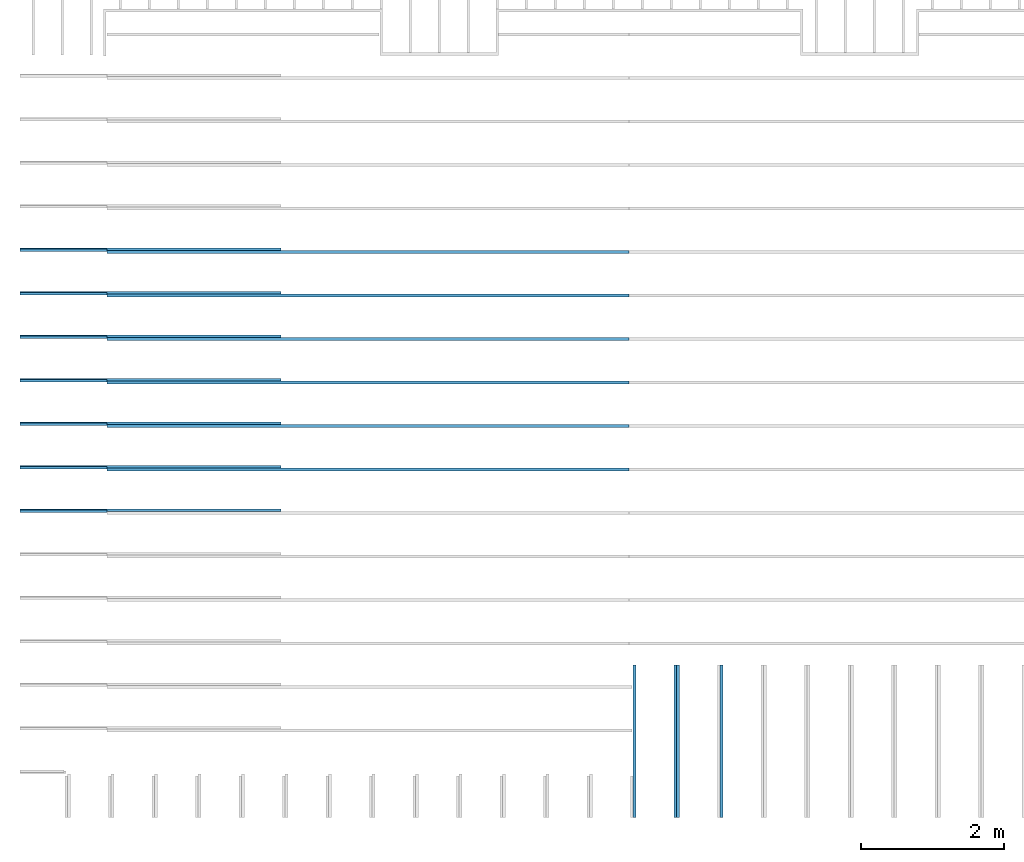
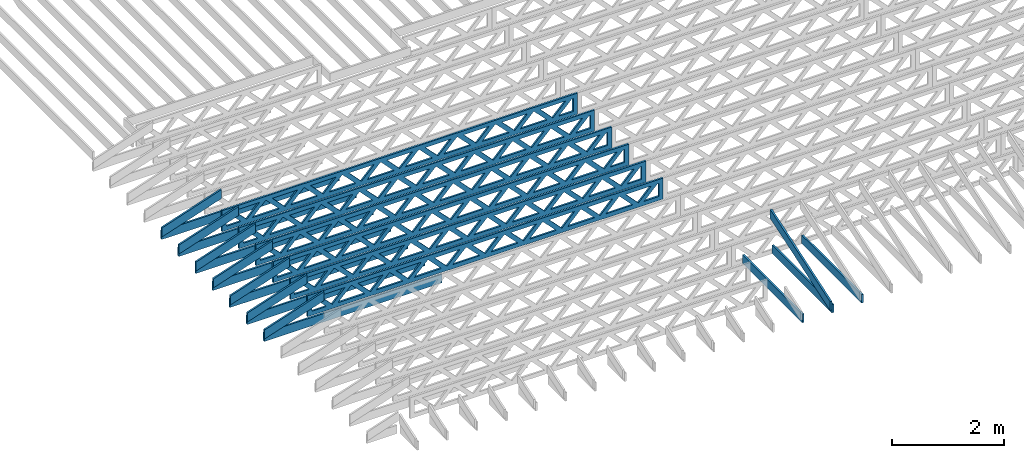
# One storey, part 2 of 18: 24 beams, 5 elements without a shape of their own.
"""IFC4 building model written with IfcOpenShell, lengths in feet."""

from ifc_helpers import new_model, entity, si_unit, converted_unit, derived_unit, direction, frame, frame_2d, origin, origin_2d_with_axis, place, context, subcontext, project, spatial, rectangle, extrude, clip, halfspace, source, transform, mapped, material, material_profile, profile_set, profile_usage, type_object, type_shapes, element, aggregate, save


model = new_model("IFC4")

# Units and contexts
model_context_1 = context("Model", 3, precision=0.0001, world=origin(), true_north=direction((6.12303176911189e-17, 1.0)))
model_context_2 = context("Model", 3, precision=0.0001, world=origin(), true_north=direction((6.12303176911189e-17, 1.0)))
body_context = subcontext(model_context_2, "Body", "Model", "MODEL_VIEW")
ifc_project = project(units=[converted_unit("LENGTHUNIT", "FOOT", entity("IfcRatioMeasure", 0.3048), si_unit("LENGTHUNIT", "METRE"), dimensions=[1, 0, 0, 0, 0, 0, 0]), converted_unit("AREAUNIT", "SQUARE FOOT", entity("IfcRatioMeasure", 0.09290304), si_unit("AREAUNIT", "SQUARE_METRE"), dimensions=[2, 0, 0, 0, 0, 0, 0]), converted_unit("VOLUMEUNIT", "CUBIC FOOT", entity("IfcRatioMeasure", 0.028316846592), si_unit("VOLUMEUNIT", "CUBIC_METRE"), dimensions=[3, 0, 0, 0, 0, 0, 0]), converted_unit("PLANEANGLEUNIT", "DEGREE", entity("IfcRatioMeasure", 0.0174532925199433), si_unit("PLANEANGLEUNIT", "RADIAN"), dimensions=[0, 0, 0, 0, 0, 0, 0]), si_unit("MASSUNIT", "GRAM", prefix="KILO"), derived_unit("MASSDENSITYUNIT", [(si_unit("MASSUNIT", "GRAM", prefix="KILO"), 1), (si_unit("LENGTHUNIT", "METRE"), -3)]), derived_unit("MOMENTOFINERTIAUNIT", [(si_unit("LENGTHUNIT", "METRE"), 4)]), si_unit("TIMEUNIT", "SECOND"), si_unit("FREQUENCYUNIT", "HERTZ"), si_unit("THERMODYNAMICTEMPERATUREUNIT", "DEGREE_CELSIUS"), derived_unit("THERMALTRANSMITTANCEUNIT", [(si_unit("MASSUNIT", "GRAM", prefix="KILO"), 1), (si_unit("THERMODYNAMICTEMPERATUREUNIT", "KELVIN"), -1), (si_unit("TIMEUNIT", "SECOND"), -3)]), derived_unit("VOLUMETRICFLOWRATEUNIT", [(si_unit("LENGTHUNIT", "METRE"), 3), (si_unit("TIMEUNIT", "SECOND"), -1)]), si_unit("ELECTRICCURRENTUNIT", "AMPERE"), si_unit("ELECTRICVOLTAGEUNIT", "VOLT"), si_unit("POWERUNIT", "WATT"), si_unit("FORCEUNIT", "NEWTON"), si_unit("ILLUMINANCEUNIT", "LUX"), si_unit("LUMINOUSFLUXUNIT", "LUMEN"), si_unit("LUMINOUSINTENSITYUNIT", "CANDELA"), derived_unit("USERDEFINED", [(si_unit("MASSUNIT", "GRAM", prefix="KILO"), -1), (si_unit("LENGTHUNIT", "METRE"), -2), (si_unit("TIMEUNIT", "SECOND"), 3), (si_unit("LUMINOUSFLUXUNIT", "LUMEN"), 1)]), derived_unit("LINEARVELOCITYUNIT", [(si_unit("LENGTHUNIT", "METRE"), 1), (si_unit("TIMEUNIT", "SECOND"), -1)]), si_unit("PRESSUREUNIT", "PASCAL"), derived_unit("USERDEFINED", [(si_unit("LENGTHUNIT", "METRE"), -2), (si_unit("MASSUNIT", "GRAM", prefix="KILO"), 1), (si_unit("TIMEUNIT", "SECOND"), -2)]), derived_unit("LINEARFORCEUNIT", [(si_unit("MASSUNIT", "GRAM", prefix="KILO"), 1), (si_unit("LENGTHUNIT", "METRE"), 1), (si_unit("TIMEUNIT", "SECOND"), -2), (si_unit("LENGTHUNIT", "METRE"), -1)]), derived_unit("PLANARFORCEUNIT", [(si_unit("MASSUNIT", "GRAM", prefix="KILO"), 1), (si_unit("LENGTHUNIT", "METRE"), 1), (si_unit("TIMEUNIT", "SECOND"), -2), (si_unit("LENGTHUNIT", "METRE"), -2)])], contexts=[model_context_1])

# Site, building, storey
site_placement = place(None, origin())
site = spatial("IfcSite", under=ifc_project, at=site_placement, CompositionType="ELEMENT")
building_placement = place(site_placement, origin())
building = spatial("IfcBuilding", under=site, at=building_placement, CompositionType="ELEMENT")
storey_placement = place(building_placement, frame((0.0, 0.0, 30.4375000000082)))
storey = spatial("IfcBuildingStorey", under=building, at=storey_placement, Name="ROOF", CompositionType="ELEMENT", Elevation=30.4375000000082)

# Assembly, beams
assembly_1_placement = place(storey_placement, origin())
assembly_1 = element("IfcElementAssembly", 1, at=assembly_1_placement, inside=storey, Name="Structural Beam System:Structural Framing System", ObjectType="Structural Beam System:Structural Framing System", AssemblyPlace="NOTDEFINED", PredefinedType="BEAM_GRID")
ifc_material_1 = material(Name="TOP CHORD OF FIELD FRAMED OVERHANG", Category="Materials")
ifc_material_profile_1 = material_profile(ifc_material_1, rectangle(XDim=0.604166666666667, YDim=0.125, at=origin_2d_with_axis()), Name="2X8 TOP CHORD")
ifc_profile_set_1 = profile_set([ifc_material_profile_1], Name="2X8 TOP CHORD")
ifc_profile_usage_1 = profile_usage(ifc_profile_set_1, cardinal=8)
beam_type_1 = type_object("IfcBeamType", Name="Dimension Lumber - Ends:2X8 TOP CHORD", PredefinedType="BEAM", material=ifc_profile_set_1)
shared_shape_1 = source(origin(), body_context, "Body", "Clipping", [
    clip(clip(extrude(rectangle(XDim=0.604166666666671, YDim=0.125, at=frame_2d((-1.83186799063151e-15, 0.0), x_axis=(1.0, 0.0))), frame((-2.10819527564865, 0.0, 0.0), z_axis=(1.0, 0.0, 0.0), x_axis=(0.0, 0.0, -1.0)), (0.0, 0.0, 1.0), 4.41772145980974), halfspace(frame((2.10819527564862, -0.0625000000000025, -0.302083333333339), z_axis=(0.948710608132914, 0.0, -0.316145823973807), x_axis=(0.0, 1.0, 0.0)), False)), halfspace(frame((-1.90686436713617, -0.0625000000000025, 0.302083333333328), z_axis=(-0.948710608132914, 0.0, 0.316145823973807), x_axis=(0.0, 1.0, 0.0)), False)),
])
type_shapes(beam_type_1, [shared_shape_1])
beam_1_placement = place(assembly_1_placement, frame((-267.833654839365, 947.945265019167, 1.93690371042362), z_axis=(-0.316227766016838, 0.0, 0.948683298050514), x_axis=(0.948683298050514, 0.0, 0.316227766016837)))
beam_1 = element("IfcBeam", 2, at=beam_1_placement, type_object=beam_type_1, material=ifc_profile_usage_1, Name="Dimension Lumber - Ends:2X8 TOP CHORD", ObjectType="Dimension Lumber - Ends:2X8 TOP CHORD", PredefinedType="BEAM", context=body_context, shape_type="MappedRepresentation", body=[
    mapped(shared_shape_1, transform((0.0, 0.0, 0.0), scale=1.0)),
])
ifc_profile_usage_2 = profile_usage(ifc_profile_set_1, cardinal=8)
beam_2_placement = place(assembly_1_placement, frame((-267.833654839365, 941.945265019167, 1.93690371042362), z_axis=(-0.316227766016838, 0.0, 0.948683298050514), x_axis=(0.948683298050514, 0.0, 0.316227766016837)))
beam_2 = element("IfcBeam", 3, at=beam_2_placement, type_object=beam_type_1, material=ifc_profile_usage_2, Name="Dimension Lumber - Ends:2X8 TOP CHORD", ObjectType="Dimension Lumber - Ends:2X8 TOP CHORD", PredefinedType="BEAM", context=body_context, shape_type="MappedRepresentation", body=[
    mapped(shared_shape_1, transform((0.0, 0.0, 0.0), scale=1.0)),
])
ifc_profile_usage_3 = profile_usage(ifc_profile_set_1, cardinal=8)
beam_3_placement = place(assembly_1_placement, frame((-267.833654839365, 935.945265019167, 1.93690371042361), z_axis=(-0.316227766016837, 0.0, 0.948683298050514), x_axis=(0.948683298050514, 0.0, 0.316227766016836)))
beam_3 = element("IfcBeam", 4, at=beam_3_placement, type_object=beam_type_1, material=ifc_profile_usage_3, Name="Dimension Lumber - Ends:2X8 TOP CHORD", ObjectType="Dimension Lumber - Ends:2X8 TOP CHORD", PredefinedType="BEAM", context=body_context, shape_type="MappedRepresentation", body=[
    mapped(shared_shape_1, transform((0.0, 0.0, 0.0), scale=1.0)),
])
ifc_profile_usage_4 = profile_usage(ifc_profile_set_1, cardinal=8)
beam_4_placement = place(assembly_1_placement, frame((-267.833654839365, 937.945265019167, 1.93690371042362), z_axis=(-0.316227766016838, 0.0, 0.948683298050514), x_axis=(0.948683298050514, 0.0, 0.316227766016837)))
beam_4 = element("IfcBeam", 5, at=beam_4_placement, type_object=beam_type_1, material=ifc_profile_usage_4, Name="Dimension Lumber - Ends:2X8 TOP CHORD", ObjectType="Dimension Lumber - Ends:2X8 TOP CHORD", PredefinedType="BEAM", context=body_context, shape_type="MappedRepresentation", body=[
    mapped(shared_shape_1, transform((0.0, 0.0, 0.0), scale=1.0)),
])
ifc_profile_usage_5 = profile_usage(ifc_profile_set_1, cardinal=8)
beam_5_placement = place(assembly_1_placement, frame((-267.833654839365, 939.945265019167, 1.93690371042362), z_axis=(-0.316227766016838, 0.0, 0.948683298050514), x_axis=(0.948683298050514, 0.0, 0.316227766016837)))
beam_5 = element("IfcBeam", 6, at=beam_5_placement, type_object=beam_type_1, material=ifc_profile_usage_5, Name="Dimension Lumber - Ends:2X8 TOP CHORD", ObjectType="Dimension Lumber - Ends:2X8 TOP CHORD", PredefinedType="BEAM", context=body_context, shape_type="MappedRepresentation", body=[
    mapped(shared_shape_1, transform((0.0, 0.0, 0.0), scale=1.0)),
])
ifc_profile_usage_6 = profile_usage(ifc_profile_set_1, cardinal=8)
beam_6_placement = place(assembly_1_placement, frame((-267.833654839365, 943.945265019167, 1.93690371042362), z_axis=(-0.316227766016838, 0.0, 0.948683298050514), x_axis=(0.948683298050514, 0.0, 0.316227766016837)))
beam_6 = element("IfcBeam", 7, at=beam_6_placement, type_object=beam_type_1, material=ifc_profile_usage_6, Name="Dimension Lumber - Ends:2X8 TOP CHORD", ObjectType="Dimension Lumber - Ends:2X8 TOP CHORD", PredefinedType="BEAM", context=body_context, shape_type="MappedRepresentation", body=[
    mapped(shared_shape_1, transform((0.0, 0.0, 0.0), scale=1.0)),
])
ifc_profile_usage_7 = profile_usage(ifc_profile_set_1, cardinal=8)
beam_7_placement = place(assembly_1_placement, frame((-267.833654839365, 945.945265019167, 1.93690371042362), z_axis=(-0.316227766016838, 0.0, 0.948683298050514), x_axis=(0.948683298050514, 0.0, 0.316227766016837)))
beam_7 = element("IfcBeam", 8, at=beam_7_placement, type_object=beam_type_1, material=ifc_profile_usage_7, Name="Dimension Lumber - Ends:2X8 TOP CHORD", ObjectType="Dimension Lumber - Ends:2X8 TOP CHORD", PredefinedType="BEAM", context=body_context, shape_type="MappedRepresentation", body=[
    mapped(shared_shape_1, transform((0.0, 0.0, 0.0), scale=1.0)),
])
aggregate(assembly_1, [beam_1, beam_2, beam_3, beam_4, beam_5, beam_6, beam_7])

assembly_2_placement = place(storey_placement, origin())
assembly_2 = element("IfcElementAssembly", 9, at=assembly_2_placement, inside=storey, Name="Structural Beam System:Structural Framing System", ObjectType="Structural Beam System:Structural Framing System", AssemblyPlace="NOTDEFINED", PredefinedType="BEAM_GRID")
ifc_material_2 = material(Name="2X8 TO ROOF", Category="Materials")
ifc_material_profile_2 = material_profile(ifc_material_2, rectangle(XDim=0.604166666666667, YDim=0.125000000000011, at=origin_2d_with_axis()), Name="2X8")
ifc_profile_set_2 = profile_set([ifc_material_profile_2], Name="2X8")
ifc_profile_usage_8 = profile_usage(ifc_profile_set_2, cardinal=8)
beam_type_2 = type_object("IfcBeamType", Name="061100 - Wood Framing:2X8", PredefinedType="BEAM", material=ifc_profile_set_2)
shared_shape_2 = source(origin(), body_context, "Body", "SweptSolid", [
    extrude(rectangle(XDim=0.604166666666667, YDim=0.125000000000011, at=origin_2d_with_axis()), frame((-6.0, 0.0, 0.0), z_axis=(1.0, 0.0, 0.0), x_axis=(0.0, 0.0, -1.0)), (0.0, 0.0, 1.0), 12.000000000033),
])
type_shapes(beam_type_2, [shared_shape_2])
beam_8_placement = place(assembly_2_placement, frame((-263.738102991821, 947.986939927769, 1.07291666665842), z_axis=(0.0, 0.0, 1.0), x_axis=(-1.0, 0.0, 0.0)))
beam_8 = element("IfcBeam", 10, at=beam_8_placement, type_object=beam_type_2, material=ifc_profile_usage_8, Name="061100 - Wood Framing:2X8", ObjectType="061100 - Wood Framing:2X8", PredefinedType="BEAM", context=body_context, shape_type="MappedRepresentation", body=[
    mapped(shared_shape_2, transform((0.0, 0.0, 0.0), scale=1.0)),
])
ifc_profile_usage_9 = profile_usage(ifc_profile_set_2, cardinal=8)
beam_9_placement = place(assembly_2_placement, frame((-263.738118066933, 945.986939927655, 1.07291666665843), z_axis=(0.0, 0.0, 1.0), x_axis=(-1.0, 0.0, 0.0)))
beam_9 = element("IfcBeam", 11, at=beam_9_placement, type_object=beam_type_2, material=ifc_profile_usage_9, Name="061100 - Wood Framing:2X8", ObjectType="061100 - Wood Framing:2X8", PredefinedType="BEAM", context=body_context, shape_type="MappedRepresentation", body=[
    mapped(shared_shape_2, transform((0.0, 0.0, 0.0), scale=1.0)),
])
ifc_profile_usage_10 = profile_usage(ifc_profile_set_2, cardinal=8)
beam_10_placement = place(assembly_2_placement, frame((-263.73816329227, 939.986939927313, 1.07291666665844), z_axis=(0.0, 0.0, 1.0), x_axis=(-1.0, 0.0, 0.0)))
beam_10 = element("IfcBeam", 12, at=beam_10_placement, type_object=beam_type_2, material=ifc_profile_usage_10, Name="061100 - Wood Framing:2X8", ObjectType="061100 - Wood Framing:2X8", PredefinedType="BEAM", context=body_context, shape_type="MappedRepresentation", body=[
    mapped(shared_shape_2, transform((0.0, 0.0, 0.0), scale=1.0)),
])
ifc_profile_usage_11 = profile_usage(ifc_profile_set_2, cardinal=8)
beam_11_placement = place(assembly_2_placement, frame((-263.738193442494, 935.986939927086, 1.07291666665846), z_axis=(0.0, 0.0, 1.0), x_axis=(-1.0, 0.0, 0.0)))
beam_11 = element("IfcBeam", 13, at=beam_11_placement, type_object=beam_type_2, material=ifc_profile_usage_11, Name="061100 - Wood Framing:2X8", ObjectType="061100 - Wood Framing:2X8", PredefinedType="BEAM", context=body_context, shape_type="MappedRepresentation", body=[
    mapped(shared_shape_2, transform((0.0, 0.0, 0.0), scale=1.0)),
])
ifc_profile_usage_12 = profile_usage(ifc_profile_set_2, cardinal=8)
beam_12_placement = place(assembly_2_placement, frame((-263.738133142046, 943.986939927541, 1.07291666665843), z_axis=(0.0, 0.0, 1.0), x_axis=(-1.0, 0.0, 0.0)))
beam_12 = element("IfcBeam", 14, at=beam_12_placement, type_object=beam_type_2, material=ifc_profile_usage_12, Name="061100 - Wood Framing:2X8", ObjectType="061100 - Wood Framing:2X8", PredefinedType="BEAM", context=body_context, shape_type="MappedRepresentation", body=[
    mapped(shared_shape_2, transform((0.0, 0.0, 0.0), scale=1.0)),
])
ifc_profile_usage_13 = profile_usage(ifc_profile_set_2, cardinal=8)
beam_13_placement = place(assembly_2_placement, frame((-263.738148217158, 941.986939927427, 1.07291666665844), z_axis=(0.0, 0.0, 1.0), x_axis=(-1.0, 0.0, 0.0)))
beam_13 = element("IfcBeam", 15, at=beam_13_placement, type_object=beam_type_2, material=ifc_profile_usage_13, Name="061100 - Wood Framing:2X8", ObjectType="061100 - Wood Framing:2X8", PredefinedType="BEAM", context=body_context, shape_type="MappedRepresentation", body=[
    mapped(shared_shape_2, transform((0.0, 0.0, 0.0), scale=1.0)),
])
ifc_profile_usage_14 = profile_usage(ifc_profile_set_2, cardinal=8)
beam_14_placement = place(assembly_2_placement, frame((-263.738178367382, 937.9869399272, 1.07291666665845), z_axis=(0.0, 0.0, 1.0), x_axis=(-1.0, 0.0, 0.0)))
beam_14 = element("IfcBeam", 16, at=beam_14_placement, type_object=beam_type_2, material=ifc_profile_usage_14, Name="061100 - Wood Framing:2X8", ObjectType="061100 - Wood Framing:2X8", PredefinedType="BEAM", context=body_context, shape_type="MappedRepresentation", body=[
    mapped(shared_shape_2, transform((0.0, 0.0, 0.0), scale=1.0)),
])
aggregate(assembly_2, [beam_8, beam_9, beam_10, beam_11, beam_12, beam_13, beam_14])

# Assembly, beam
assembly_3_placement = place(storey_placement, origin())
assembly_3 = element("IfcElementAssembly", 17, at=assembly_3_placement, inside=storey, Name="Structural Beam System:Structural Framing System", ObjectType="Structural Beam System:Structural Framing System", AssemblyPlace="NOTDEFINED", PredefinedType="BEAM_GRID")
ifc_profile_usage_15 = profile_usage(ifc_profile_set_1, cardinal=8)
beam_type_3 = type_object("IfcBeamType", Name="Dimension Lumber - Ends:2X8 TOP CHORD", PredefinedType="BEAM", material=ifc_profile_set_1)
shared_shape_3 = source(origin(), body_context, "Body", "Clipping", [
    clip(clip(extrude(rectangle(XDim=0.604166666666667, YDim=0.125, at=origin_2d_with_axis()), frame((-3.68932423085928, 0.0, 0.0), z_axis=(1.0, 0.0, 0.0), x_axis=(0.0, 0.0, -1.0)), (0.0, 0.0, 1.0), 7.57997937023103), halfspace(frame((3.68932423085925, -0.0625000000000025, -0.302083333333339), z_axis=(0.948710608132914, 0.0, -0.316145823973806), x_axis=(0.0, 1.0, 0.0)), False)), halfspace(frame((-3.4879933223468, -0.0625000000000025, 0.302083333333328), z_axis=(-0.948710608132914, 0.0, 0.316145823973805), x_axis=(0.0, 1.0, 0.0)), False)),
])
type_shapes(beam_type_3, [shared_shape_3])
beam_15_placement = place(assembly_3_placement, frame((-239.613158541548, 925.266392269532, 2.43688759934747), z_axis=(0.0, -0.316227766016849, 0.94868329805051), x_axis=(0.0, 0.94868329805051, 0.316227766016849)))
beam_15 = element("IfcBeam", 18, at=beam_15_placement, type_object=beam_type_3, material=ifc_profile_usage_15, Name="Dimension Lumber - Ends:2X8 TOP CHORD", ObjectType="Dimension Lumber - Ends:2X8 TOP CHORD", PredefinedType="BEAM", context=body_context, shape_type="MappedRepresentation", body=[
    mapped(shared_shape_3, transform((0.0, 0.0, 0.0), scale=1.0)),
])
aggregate(assembly_3, [beam_15])

# Assembly, beams
assembly_4_placement = place(storey_placement, origin())
assembly_4 = element("IfcElementAssembly", 19, at=assembly_4_placement, inside=storey, Name="Structural Beam System:Structural Framing System", ObjectType="Structural Beam System:Structural Framing System", AssemblyPlace="NOTDEFINED", PredefinedType="BEAM_GRID")
ifc_material_3 = material(Name="BOTTOM CHORD OF FIELD FRAMED OVERHANG", Category="Materials")
ifc_material_profile_3 = material_profile(ifc_material_3, rectangle(XDim=0.604166666666667, YDim=0.125000000000011, at=origin_2d_with_axis()), Name="2X8 - BOTTOM CHORD")
ifc_profile_set_3 = profile_set([ifc_material_profile_3], Name="2X8 - BOTTOM CHORD")
ifc_profile_usage_16 = profile_usage(ifc_profile_set_3, cardinal=8)
beam_type_4 = type_object("IfcBeamType", Name="061100 - Wood Framing:2X8 - BOTTOM CHORD", PredefinedType="BEAM", material=ifc_profile_set_3)
shared_shape_4 = source(origin(), body_context, "Body", "SweptSolid", [
    extrude(rectangle(XDim=0.604166666666667, YDim=0.125000000000011, at=origin_2d_with_axis()), frame((-3.49999999999926, 0.0, 0.0), z_axis=(1.0, 0.0, 0.0), x_axis=(0.0, 0.0, -1.0)), (0.0, 0.0, 1.0), 6.99999999999852),
])
type_shapes(beam_type_4, [shared_shape_4])
beam_16_placement = place(assembly_4_placement, frame((-239.488158437574, 925.361925732779, 1.07291666665406), z_axis=(0.0, 0.0, 1.0), x_axis=(0.0, -1.0, 0.0)))
beam_16 = element("IfcBeam", 20, at=beam_16_placement, type_object=beam_type_4, material=ifc_profile_usage_16, Name="061100 - Wood Framing:2X8 - BOTTOM CHORD", ObjectType="061100 - Wood Framing:2X8 - BOTTOM CHORD", PredefinedType="BEAM", context=body_context, shape_type="MappedRepresentation", body=[
    mapped(shared_shape_4, transform((0.0, 0.0, 0.0), scale=1.0)),
])
ifc_profile_usage_17 = profile_usage(ifc_profile_set_3, cardinal=8)
beam_17_placement = place(assembly_4_placement, frame((-237.488158437574, 925.361926235282, 1.07291666665406), z_axis=(0.0, 0.0, 1.0), x_axis=(0.0, -1.0, 0.0)))
beam_17 = element("IfcBeam", 21, at=beam_17_placement, type_object=beam_type_4, material=ifc_profile_usage_17, Name="061100 - Wood Framing:2X8 - BOTTOM CHORD", ObjectType="061100 - Wood Framing:2X8 - BOTTOM CHORD", PredefinedType="BEAM", context=body_context, shape_type="MappedRepresentation", body=[
    mapped(shared_shape_4, transform((0.0, 0.0, 0.0), scale=1.0)),
])
ifc_profile_usage_18 = profile_usage(ifc_profile_set_3, cardinal=8)
beam_18_placement = place(assembly_4_placement, frame((-241.488158437574, 925.361925230275, 1.07291666665406), z_axis=(0.0, 0.0, 1.0), x_axis=(0.0, -1.0, 0.0)))
beam_18 = element("IfcBeam", 22, at=beam_18_placement, type_object=beam_type_4, material=ifc_profile_usage_18, Name="061100 - Wood Framing:2X8 - BOTTOM CHORD", ObjectType="061100 - Wood Framing:2X8 - BOTTOM CHORD", PredefinedType="BEAM", context=body_context, shape_type="MappedRepresentation", body=[
    mapped(shared_shape_4, transform((0.0, 0.0, 0.0), scale=1.0)),
])
aggregate(assembly_4, [beam_16, beam_17, beam_18])

assembly_5_placement = place(storey_placement, origin())
assembly_5 = element("IfcElementAssembly", 23, at=assembly_5_placement, inside=storey, Name="Structural Beam System:Structural Framing System", ObjectType="Structural Beam System:Structural Framing System", AssemblyPlace="NOTDEFINED", PredefinedType="BEAM_GRID")
ifc_material_4 = material(Name="WOOD TRUSS", Category="Materials")
ifc_material_profile_4 = material_profile(ifc_material_4, rectangle(XDim=1.73473973950632, YDim=0.125, at=origin_2d_with_axis()))
ifc_material_profile_5 = material_profile(ifc_material_4, rectangle(XDim=1.73473973950633, YDim=0.125, at=frame_2d((-1.11022302462516e-16, 0.0), x_axis=(1.0, 0.0))))
ifc_material_profile_6 = material_profile(ifc_material_4, rectangle(XDim=1.73473973950632, YDim=0.125, at=origin_2d_with_axis()))
ifc_material_profile_7 = material_profile(ifc_material_4, rectangle(XDim=1.73473973950633, YDim=0.125, at=origin_2d_with_axis()))
ifc_material_profile_8 = material_profile(ifc_material_4, rectangle(XDim=1.73473973950632, YDim=0.125, at=frame_2d((-5.55111512312578e-17, 0.0), x_axis=(1.0, 0.0))))
ifc_material_profile_9 = material_profile(ifc_material_4, rectangle(XDim=1.73473973950633, YDim=0.125, at=frame_2d((-2.77555756156289e-16, 0.0), x_axis=(1.0, 0.0))))
ifc_material_profile_10 = material_profile(ifc_material_4, rectangle(XDim=1.73473973950632, YDim=0.125, at=frame_2d((-4.9960036108132e-16, 0.0), x_axis=(1.0, 0.0))))
ifc_material_profile_11 = material_profile(ifc_material_4, rectangle(XDim=1.73473973950633, YDim=0.125, at=frame_2d((4.44089209850063e-16, 0.0), x_axis=(1.0, 0.0))))
ifc_material_profile_12 = material_profile(ifc_material_4, rectangle(XDim=1.73473973950632, YDim=0.125, at=origin_2d_with_axis()))
ifc_material_profile_13 = material_profile(ifc_material_4, rectangle(XDim=1.73473973950633, YDim=0.125, at=frame_2d((-4.9960036108132e-16, 0.0), x_axis=(1.0, 0.0))))
ifc_material_profile_14 = material_profile(ifc_material_4, rectangle(XDim=0.291666666666664, YDim=0.125, at=frame_2d((-2.77555756156289e-17, 0.0), x_axis=(1.0, 0.0))))
ifc_material_profile_15 = material_profile(ifc_material_4, rectangle(XDim=0.291666666666628, YDim=0.124999999999995, at=frame_2d((-5.55111512312578e-17, 0.0), x_axis=(1.0, 0.0))))
ifc_material_profile_16 = material_profile(ifc_material_4, rectangle(XDim=0.916666666666666, YDim=0.125000000000003, at=frame_2d((-2.77555756156289e-17, 0.0), x_axis=(1.0, 0.0))))
ifc_material_profile_17 = material_profile(ifc_material_4, rectangle(XDim=0.916666666666651, YDim=0.125, at=frame_2d((-2.77555756156289e-17, 0.0), x_axis=(1.0, 0.0))))
ifc_profile_set_4 = profile_set([ifc_material_profile_4, ifc_material_profile_5, ifc_material_profile_6, ifc_material_profile_7, ifc_material_profile_8, ifc_material_profile_9, ifc_material_profile_10, ifc_material_profile_11, ifc_material_profile_12, ifc_material_profile_13, ifc_material_profile_14, ifc_material_profile_15, ifc_material_profile_16, ifc_material_profile_17])
ifc_profile_usage_19 = profile_usage(ifc_profile_set_4, cardinal=8)
beam_type_5 = type_object("IfcBeamType", PredefinedType="BEAM", material=ifc_profile_set_4)
shared_shape_5 = source(origin(), body_context, "Body", "SweptSolid", [
    extrude(rectangle(XDim=1.73473973950632, YDim=0.125, at=frame_2d((8.88178419700125e-16, 0.0), x_axis=(1.0, 0.0))), frame((8.27006284966195, 0.0, 0.101118361020562), z_axis=(0.720569184836762, 0.0, -0.693383046997606), x_axis=(0.693383046997606, 0.0, 0.720569184836762)), (0.0, 0.0, 1.0), 0.291666666666667),
    extrude(rectangle(XDim=1.73473973950633, YDim=0.125, at=frame_2d((4.9960036108132e-16, 0.0), x_axis=(1.0, 0.0))), frame((7.01977697598868, 0.0, -0.101118361020407), z_axis=(0.720569184836758, 0.0, 0.69338304699761), x_axis=(0.69338304699761, 0.0, -0.720569184836758)), (0.0, 0.0, 1.0), 0.291666666666667),
    extrude(rectangle(XDim=1.73473973950632, YDim=0.125, at=origin_2d_with_axis()), frame((5.68672854334628, 0.0, 0.101118361020562), z_axis=(0.720569184836762, 0.0, -0.693383046997606), x_axis=(0.693383046997606, 0.0, 0.720569184836762)), (0.0, 0.0, 1.0), 0.291666666666667),
    extrude(rectangle(XDim=1.73473973950633, YDim=0.125, at=frame_2d((-4.9960036108132e-16, 0.0), x_axis=(1.0, 0.0))), frame((4.43644266967301, 0.0, -0.101118361020407), z_axis=(0.720569184836758, 0.0, 0.69338304699761), x_axis=(0.69338304699761, 0.0, -0.720569184836758)), (0.0, 0.0, 1.0), 0.291666666666667),
    extrude(rectangle(XDim=1.73473973950632, YDim=0.125, at=frame_2d((3.33066907387547e-16, 0.0), x_axis=(1.0, 0.0))), frame((3.10339423703061, 0.0, 0.101118361020562), z_axis=(0.720569184836762, 0.0, -0.693383046997606), x_axis=(0.693383046997606, 0.0, 0.720569184836762)), (0.0, 0.0, 1.0), 0.291666666666667),
    extrude(rectangle(XDim=1.73473973950633, YDim=0.125, at=frame_2d((-1.11022302462516e-16, 0.0), x_axis=(1.0, 0.0))), frame((1.85310836335734, 0.0, -0.101118361020407), z_axis=(0.720569184836758, 0.0, 0.69338304699761), x_axis=(0.69338304699761, 0.0, -0.720569184836758)), (0.0, 0.0, 1.0), 0.291666666666666),
    extrude(rectangle(XDim=1.73473973950632, YDim=0.125, at=frame_2d((5.55111512312578e-17, 0.0), x_axis=(1.0, 0.0))), frame((0.520059930714937, 0.0, 0.101118361020562), z_axis=(0.720569184836762, 0.0, -0.693383046997606), x_axis=(0.693383046997606, 0.0, 0.720569184836762)), (0.0, 0.0, 1.0), 0.291666666666667),
    extrude(rectangle(XDim=1.73473973950633, YDim=0.125, at=origin_2d_with_axis()), frame((-0.730225942958334, 0.0, -0.101118361020407), z_axis=(0.720569184836758, 0.0, 0.69338304699761), x_axis=(0.69338304699761, 0.0, -0.720569184836758)), (0.0, 0.0, 1.0), 0.291666666666666),
    extrude(rectangle(XDim=1.73473973950632, YDim=0.125, at=frame_2d((-5.55111512312578e-17, 0.0), x_axis=(1.0, 0.0))), frame((-2.06327437560074, 0.0, 0.101118361020562), z_axis=(0.720569184836762, 0.0, -0.693383046997606), x_axis=(0.693383046997606, 0.0, 0.720569184836762)), (0.0, 0.0, 1.0), 0.291666666666667),
    extrude(rectangle(XDim=1.73473973950633, YDim=0.125, at=frame_2d((-2.77555756156289e-16, 0.0), x_axis=(1.0, 0.0))), frame((-3.31356024927401, 0.0, -0.101118361020407), z_axis=(0.720569184836758, 0.0, 0.69338304699761), x_axis=(0.69338304699761, 0.0, -0.720569184836758)), (0.0, 0.0, 1.0), 0.291666666666666),
    extrude(rectangle(XDim=1.73473973950632, YDim=0.125, at=origin_2d_with_axis()), frame((-4.64660868191641, 0.0, 0.101118361020562), z_axis=(0.720569184836762, 0.0, -0.693383046997606), x_axis=(0.693383046997606, 0.0, 0.720569184836762)), (0.0, 0.0, 1.0), 0.291666666666667),
    extrude(rectangle(XDim=1.73473973950633, YDim=0.125, at=frame_2d((-4.9960036108132e-16, 0.0), x_axis=(1.0, 0.0))), frame((-5.89689455558968, 0.0, -0.101118361020407), z_axis=(0.720569184836758, 0.0, 0.69338304699761), x_axis=(0.69338304699761, 0.0, -0.720569184836758)), (0.0, 0.0, 1.0), 0.291666666666667),
    extrude(rectangle(XDim=1.73473973950632, YDim=0.125, at=frame_2d((5.55111512312578e-16, 0.0), x_axis=(1.0, 0.0))), frame((-7.22994298823208, 0.0, 0.101118361020562), z_axis=(0.720569184836762, 0.0, -0.693383046997606), x_axis=(0.693383046997606, 0.0, 0.720569184836762)), (0.0, 0.0, 1.0), 0.291666666666667),
    extrude(rectangle(XDim=1.73473973950633, YDim=0.125, at=origin_2d_with_axis()), frame((-8.48022886190535, 0.0, -0.101118361020407), z_axis=(0.720569184836758, 0.0, 0.69338304699761), x_axis=(0.69338304699761, 0.0, -0.720569184836758)), (0.0, 0.0, 1.0), 0.291666666666666),
    extrude(rectangle(XDim=1.73473973950632, YDim=0.125, at=frame_2d((-8.88178419700125e-16, 0.0), x_axis=(1.0, 0.0))), frame((10.8533971559776, 0.0, 0.101118361020503), z_axis=(0.720569184836762, 0.0, -0.693383046997606), x_axis=(0.693383046997606, 0.0, 0.720569184836762)), (0.0, 0.0, 1.0), 0.291666666666664),
    extrude(rectangle(XDim=1.73473973950633, YDim=0.125, at=origin_2d_with_axis()), frame((9.60311128230435, 0.0, -0.101118361020466), z_axis=(0.720569184836758, 0.0, 0.69338304699761), x_axis=(0.69338304699761, 0.0, -0.720569184836758)), (0.0, 0.0, 1.0), 0.291666666666666),
    extrude(rectangle(XDim=1.73473973950632, YDim=0.125, at=frame_2d((8.88178419700125e-16, 0.0), x_axis=(1.0, 0.0))), frame((-9.81327729454775, 0.0, 0.101118361020564), z_axis=(0.720569184836762, 0.0, -0.693383046997606), x_axis=(0.693383046997606, 0.0, 0.720569184836762)), (0.0, 0.0, 1.0), 0.291666666666667),
    extrude(rectangle(XDim=1.73473973950633, YDim=0.125, at=origin_2d_with_axis()), frame((-11.063563168221, 0.0, -0.101118361020405), z_axis=(0.720569184836758, 0.0, 0.69338304699761), x_axis=(0.69338304699761, 0.0, -0.720569184836758)), (0.0, 0.0, 1.0), 0.291666666666666),
    extrude(rectangle(XDim=0.291666666666664, YDim=0.125, at=frame_2d((-2.77555756156289e-17, 0.0), x_axis=(1.0, 0.0))), frame((-12.0000038919293, 0.0, 0.604166666666611), z_axis=(1.0, 0.0, 0.0), x_axis=(0.0, 0.0, -1.0)), (0.0, 0.0, 1.0), 24.0000077838585),
    extrude(rectangle(XDim=0.291666666666628, YDim=0.124999999999995, at=frame_2d((-5.55111512312578e-17, 0.0), x_axis=(1.0, 0.0))), frame((-12.0000038919291, 0.0, -0.604166666666693), z_axis=(1.0, 0.0, 0.0), x_axis=(0.0, 0.0, -1.0)), (0.0, 0.0, 1.0), 24.0000077838583),
    extrude(rectangle(XDim=0.916666666666666, YDim=0.125000000000003, at=frame_2d((-2.77555756156289e-17, 0.0), x_axis=(1.0, 0.0))), frame((11.7083372252626, 0.0, 0.0), z_axis=(1.0, 0.0, 0.0), x_axis=(0.0, 0.0, -1.0)), (0.0, 0.0, 1.0), 0.291666666666687),
    extrude(rectangle(XDim=0.916666666666651, YDim=0.125, at=frame_2d((-2.77555756156289e-17, 0.0), x_axis=(1.0, 0.0))), frame((-12.0000038919293, 0.0, 0.0), z_axis=(1.0, 0.0, 0.0), x_axis=(0.0, 0.0, -1.0)), (0.0, 0.0, 1.0), 0.291666666666687),
])
type_shapes(beam_type_5, [shared_shape_5])
beam_19_placement = place(assembly_5_placement, frame((-253.738164377457, 937.861934882651, 0.749999999991669)))
beam_19 = element("IfcBeam", 24, at=beam_19_placement, type_object=beam_type_5, material=ifc_profile_usage_19, PredefinedType="BEAM", context=body_context, shape_type="MappedRepresentation", body=[
    mapped(shared_shape_5, transform((0.0, 0.0, 0.0), scale=1.0)),
])
ifc_profile_usage_20 = profile_usage(ifc_profile_set_4, cardinal=8)
beam_20_placement = place(assembly_5_placement, frame((-253.738164377457, 939.861934882651, 0.749999999991662)))
beam_20 = element("IfcBeam", 25, at=beam_20_placement, type_object=beam_type_5, material=ifc_profile_usage_20, PredefinedType="BEAM", context=body_context, shape_type="MappedRepresentation", body=[
    mapped(shared_shape_5, transform((0.0, 0.0, 0.0), scale=1.0)),
])
ifc_profile_usage_21 = profile_usage(ifc_profile_set_4, cardinal=8)
beam_21_placement = place(assembly_5_placement, frame((-253.738164377457, 941.861934882651, 0.749999999991658)))
beam_21 = element("IfcBeam", 26, at=beam_21_placement, type_object=beam_type_5, material=ifc_profile_usage_21, PredefinedType="BEAM", context=body_context, shape_type="MappedRepresentation", body=[
    mapped(shared_shape_5, transform((0.0, 0.0, 0.0), scale=1.0)),
])
ifc_profile_usage_22 = profile_usage(ifc_profile_set_4, cardinal=8)
beam_22_placement = place(assembly_5_placement, frame((-253.738164377457, 943.861934882651, 0.749999999991651)))
beam_22 = element("IfcBeam", 27, at=beam_22_placement, type_object=beam_type_5, material=ifc_profile_usage_22, PredefinedType="BEAM", context=body_context, shape_type="MappedRepresentation", body=[
    mapped(shared_shape_5, transform((0.0, 0.0, 0.0), scale=1.0)),
])
ifc_profile_usage_23 = profile_usage(ifc_profile_set_4, cardinal=8)
beam_23_placement = place(assembly_5_placement, frame((-253.738164377457, 947.861934882651, 0.74999999999164)))
beam_23 = element("IfcBeam", 28, at=beam_23_placement, type_object=beam_type_5, material=ifc_profile_usage_23, PredefinedType="BEAM", context=body_context, shape_type="MappedRepresentation", body=[
    mapped(shared_shape_5, transform((0.0, 0.0, 0.0), scale=1.0)),
])
ifc_profile_usage_24 = profile_usage(ifc_profile_set_4, cardinal=8)
beam_24_placement = place(assembly_5_placement, frame((-253.738164377457, 945.861934882651, 0.749999999991648)))
beam_24 = element("IfcBeam", 29, at=beam_24_placement, type_object=beam_type_5, material=ifc_profile_usage_24, PredefinedType="BEAM", context=body_context, shape_type="MappedRepresentation", body=[
    mapped(shared_shape_5, transform((0.0, 0.0, 0.0), scale=1.0)),
])
aggregate(assembly_5, [beam_19, beam_20, beam_21, beam_22, beam_23, beam_24])

save(model, "model.ifc")
